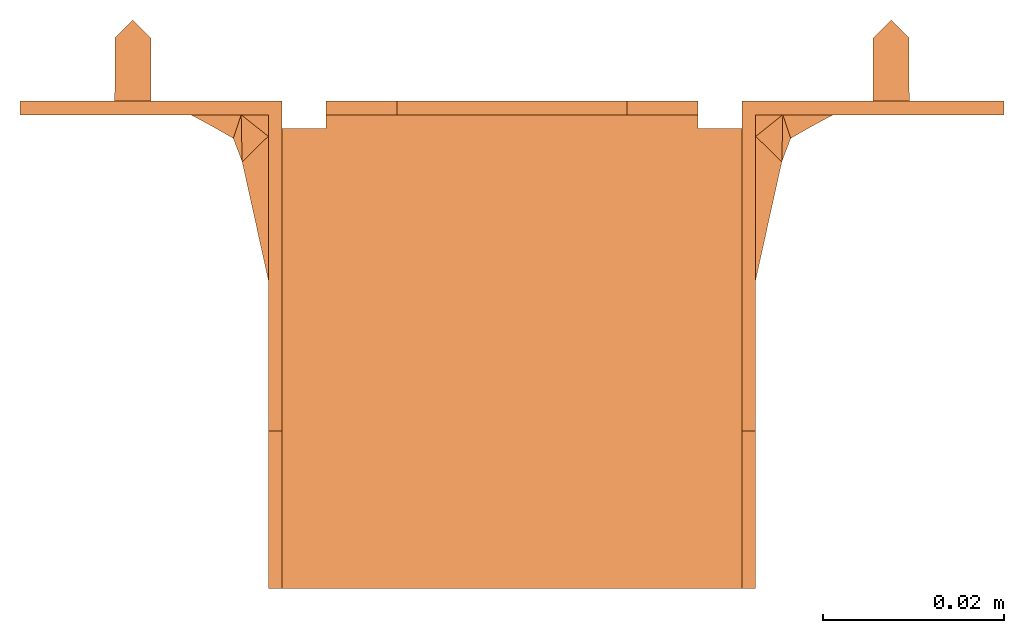
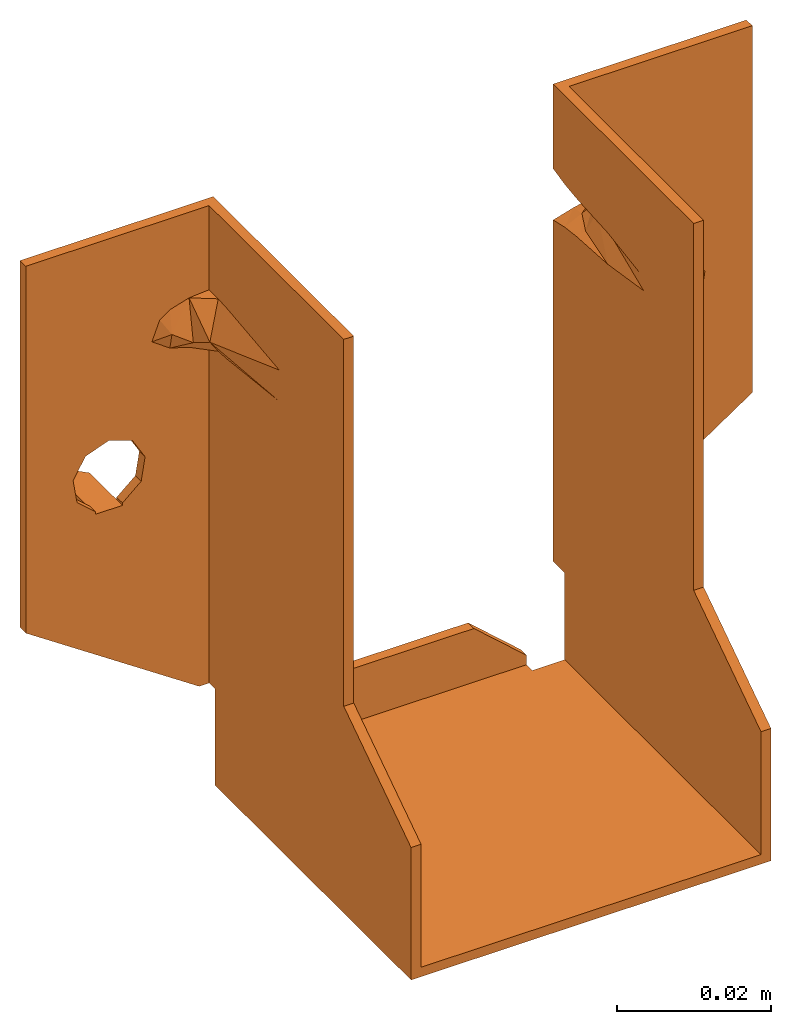
# One storey: 1 proxy.
"""IFC2X3 building model written with IfcOpenShell, lengths in millimetres."""

from ifc_helpers import new_model, entity, si_unit, converted_unit, derived_unit, direction, origin, place, context, subcontext, project, spatial, faceted_brep, source, transform, mapped, material, element, save


model = new_model("IFC2X3")

# Units and contexts
model_context = context("Model", 3, precision=0.01, world=origin(), true_north=direction((6.12303176911189e-17, 1.0)))
context_of_model = context(None, 3, precision=0.01, world=origin(), true_north=direction((6.12303176911189e-17, 1.0)))
body_context = subcontext(model_context, "Body", "Model", "MODEL_VIEW")
ifc_project = project(units=[si_unit("LENGTHUNIT", "METRE", prefix="MILLI"), converted_unit("AREAUNIT", "SQUARE FOOT", entity("IfcRatioMeasure", 0.09290304), si_unit("AREAUNIT", "SQUARE_METRE"), dimensions=[2, 0, 0, 0, 0, 0, 0]), converted_unit("VOLUMEUNIT", "CUBIC FOOT", entity("IfcRatioMeasure", 0.028316846592), si_unit("VOLUMEUNIT", "CUBIC_METRE"), dimensions=[3, 0, 0, 0, 0, 0, 0]), converted_unit("PLANEANGLEUNIT", "DEGREE", entity("IfcRatioMeasure", 0.0174532925199433), si_unit("PLANEANGLEUNIT", "RADIAN"), dimensions=[0, 0, 0, 0, 0, 0, 0]), si_unit("MASSUNIT", "GRAM", prefix="KILO"), si_unit("TIMEUNIT", "SECOND"), si_unit("FREQUENCYUNIT", "HERTZ"), si_unit("THERMODYNAMICTEMPERATUREUNIT", "DEGREE_CELSIUS"), derived_unit("THERMALTRANSMITTANCEUNIT", [(si_unit("MASSUNIT", "GRAM", prefix="KILO"), 1), (si_unit("THERMODYNAMICTEMPERATUREUNIT", "KELVIN"), -1), (si_unit("TIMEUNIT", "SECOND"), -3)]), derived_unit("VOLUMETRICFLOWRATEUNIT", [(si_unit("LENGTHUNIT", "METRE"), 3), (si_unit("TIMEUNIT", "SECOND"), -1)]), si_unit("ELECTRICCURRENTUNIT", "AMPERE"), si_unit("ELECTRICVOLTAGEUNIT", "VOLT"), si_unit("POWERUNIT", "WATT"), si_unit("FORCEUNIT", "NEWTON"), si_unit("ILLUMINANCEUNIT", "LUX"), si_unit("LUMINOUSFLUXUNIT", "LUMEN"), si_unit("LUMINOUSINTENSITYUNIT", "CANDELA"), si_unit("PRESSUREUNIT", "PASCAL")], contexts=[model_context, context_of_model])

# Site, building, storey
site_placement = place(None, origin())
site = spatial("IfcSite", under=ifc_project, at=site_placement, CompositionType="ELEMENT")
building_placement = place(site_placement, origin())
building = spatial("IfcBuilding", under=site, at=building_placement, CompositionType="ELEMENT")
storey_placement = place(building_placement, origin())
storey = spatial("IfcBuildingStorey", under=building, at=storey_placement, Name="Level 1", CompositionType="ELEMENT", Elevation=0.0)

# Proxy
ifc_material = material(Name="Galvanised")
shared_shape = source(origin(), body_context, "Body", "Brep", [
    faceted_brep([(-25.5, 0.0, 89.5), (-25.5000000000001, 0.0, 76.0680447925519), (-28.5164626396647, 0.0, 75.1703317636631), (-31.5853310986962, 0.0, 74.4944747377399), (-31.9884182385809, 0.0, 74.4262128764024), (-32.3912057400425, 0.0, 74.35627635071), (-54.5, 0.0, 89.5), (-35.1100733723525, 0.0, 72.9234667501482), (-36.8624233395133, 0.0, 72.0), (-34.1435557017103, 0.0, 70.5671903965434), (-42.0, 0.0, 57.5), (-32.3912057400424, 0.0, 69.64372364929), (-38.4911282799051, 0.0, 56.2353062760463), (-31.988418238207, 0.0, 69.573787123533), (-31.5853310979541, 0.0, 69.5055252620951), (-28.5164626393064, 0.0, 68.8296682361884), (-25.5, 0.0, 67.9319552074545), (-36.5959467571056, 0.0, 53.0228433643336), (-37.1860278598334, 0.0, 49.3399864222716), (-25.5, 0.0, 13.7727785620969), (-40.0, 0.0, 45.0), (-28.5, 0.0, 13.7727785620969), (-54.5, 0.0, 31.31), (-44.0, 0.0, 45.0), (-46.8139721401667, 0.0, 49.3399864222716), (-47.4040532428946, 0.0, 53.0228433643336), (-45.5088717200951, 0.0, 56.2353062760463), (-44.0050000000001, 0.0, 46.5), (-44.0100000000001, 0.0, 46.8804394719859), (-39.9950000000001, 0.0, 46.5), (-39.9900000000001, 0.0, 46.8804394719859), (25.5000000000002, 0.0, 89.5), (54.5000000000002, 0.0, 89.5), (32.3912057400424, 0.0, 74.35627635071), (31.9884182385809, 0.0, 74.4262128764024), (31.5853310986874, 0.0, 74.4944747376867), (28.5164626396627, 0.0, 75.1703317636636), (25.5000000000001, 0.0, 76.0680447925519), (35.1100733723523, 0.0, 72.9234667501483), (36.8624233395133, 0.0, 72.0), (45.5088717200951, 0.0, 56.2353062760463), (47.4040532428946, 0.0, 53.0228433643336), (54.5000000000001, 0.0, 31.31), (46.8139721401668, 0.0, 49.3399864222716), (44.0, 0.0, 45.0), (40.0, 0.0, 45.0), (28.5, 0.0, 13.7727785620969), (25.5, 0.0, 13.7727785620969), (37.1860278598334, 0.0, 49.3399864222716), (25.5000000000001, 0.0, 67.9319552074546), (36.5959467571056, 0.0, 53.0228433643336), (38.4911282799051, 0.0, 56.2353062760463), (28.5164626393065, 0.0, 68.8296682361884), (31.5853310979472, 0.0, 69.505525262137), (31.988418238207, 0.0, 69.573787123533), (32.3912057400424, 0.0, 69.64372364929), (42.0, 0.0, 57.5), (34.1435557017102, 0.0, 70.5671903965434), (39.9950000000001, 0.0, 46.5), (39.9900000000001, 0.0, 46.8804394719859), (44.0050000000001, 0.0, 46.5), (44.0100000000001, 0.0, 46.8804394719859), (-12.75, 0.0, 8.5), (12.75, 0.0, 8.5), (20.625, 0.0, 1.50000000000001), (20.625, 0.0, -1.49999999999998), (-20.625, 0.0, -1.49999999999999), (-20.625, 0.0, 1.5), (-27.0, -1.5, 89.5), (-27.0, -19.7785075183965, 74.4781276587163), (-27.0, -36.5, 89.5), (-27.0, -6.25628514900084, 76.0015865398657), (-27.0, -3.88236220929079, 76.159855910213), (-27.0, -1.50000000000001, 76.1478993905245), (-27.0, -24.9500000000007, 72.0), (-27.0, -19.7785075183964, 69.5218723412837), (-27.0, -36.5, 31.31), (-27.0, -6.25628514899862, 67.9984134601342), (-27.0, -3.0, 13.7727785620969), (-27.0, -3.89258332769992, 67.8407422939264), (-27.0, -1.5, 67.8521006094755), (-27.0, -1.5, 13.7727785620969), (-27.0, -3.0, -1.49999999999999), (-27.0, -54.0, -1.49999999999999), (-27.0, -54.0, 19.5061009552575), (27.0, -36.5, 31.31), (27.0, -54.0, 19.5061009552576), (27.0, -54.0, -1.49999999999998), (27.0, -3.0, -1.49999999999998), (27.0, -3.0, 13.7727785620969), (27.0, -6.25628514900161, 67.9984134601343), (27.0, -19.7785075183968, 69.5218723412838), (27.0, -24.950000000001, 72.0), (27.0, -36.5, 89.5), (27.0, -3.88236220929137, 67.8401440897871), (27.0, -1.50000000000116, 67.8521006094754), (27.0, -1.49999999999999, 13.7727785620969), (27.0, -19.7785075183969, 74.4781276587163), (27.0, -1.50000000000001, 89.5), (27.0, -6.25628514899864, 76.0015865398658), (27.0, -3.89258332769992, 76.1592577060736), (27.0, -1.5, 76.1478993905245), (-28.3744321404696, -2.48961956164226, 69.505525262095), (-26.1302855306788, -6.11853590953504, 69.2411981416627), (-25.5, -2.98683164318899, 68.5972304361922), (-25.5000000000001, -6.01870848852047, 68.9768710212308), (-26.7605710613576, -6.21836333055625, 69.505525262095), (-20.625, -1.5, 0.0), (-20.625, -1.5, 1.5), (-20.625, -3.0, -1.5), (-20.625, -3.0, 0.0), (20.625, -1.5, 1.50000000000001), (20.625, -1.5, 0.0), (20.625, -3.0, 0.0), (20.625, -3.0, -1.49999999999999), (-25.5, -3.0, 13.7727785620969), (-25.5, -3.0, 0.0), (25.5, -3.0, 0.0), (25.5, -3.0, 13.7727785620969), (12.75, -1.50000000000001, 8.5), (-12.75, -1.50000000000001, 8.5), (-30.001194607727, -1.50000000000001, 75.9217007968475), (-32.8785852843918, -1.50000000000001, 75.0423700295935), (-54.5, -1.50000000000001, 89.5), (-34.4052679931513, -1.50000000000001, 73.942091087405), (-37.1000000000001, -1.50000000000001, 72.0), (-45.5088717200951, -1.50000000000001, 56.2353062760463), (-47.4040532428946, -1.50000000000001, 53.0228433643336), (-54.5000000000001, -1.50000000000001, 31.31), (-46.8139721401667, -1.50000000000001, 49.3399864222716), (-44.0100000000001, -1.50000000000001, 46.5), (-39.9900000000001, -1.50000000000001, 46.5), (-28.5, -1.49999999999999, 13.7727785620969), (-37.1860278598334, -1.50000000000001, 49.3399864222716), (-36.5959467571056, -1.50000000000001, 53.0228433643336), (-29.9983767666607, -1.50000000000001, 68.0776222514754), (-38.4911282799051, -1.50000000000001, 56.2353062760463), (-32.8785852843918, -1.50000000000001, 68.9576299704065), (-42.0, -1.50000000000001, 57.5), (-35.5733172762352, -1.50000000000001, 70.8997210469971), (-39.9900000000001, -1.50000000000001, 46.8804394719859), (-44.0100000000001, -1.50000000000001, 46.8804394719859), (54.5000000000002, -1.50000000000001, 89.5), (32.8785852843917, -1.50000000000001, 75.0423700295936), (34.405267993151, -1.5, 73.9420910874052), (37.1000000000001, -1.50000000000001, 72.0), (45.5088717200951, -1.50000000000001, 56.2353062760463), (47.4040532428946, -1.50000000000001, 53.0228433643336), (54.5000000000001, -1.50000000000001, 31.31), (29.9983767666607, -1.50000000000001, 75.9223777485246), (35.5733172762347, -1.50000000000001, 70.8997210469968), (42.0, -1.50000000000001, 57.5), (32.8785852843918, -1.50000000000001, 68.9576299704064), (38.4911282799051, -1.50000000000001, 56.2353062760463), (30.0011946077271, -1.50000000000001, 68.0782992031525), (36.5959467571056, -1.50000000000001, 53.0228433643336), (37.1860278598334, -1.50000000000001, 49.3399864222716), (39.9900000000001, -1.50000000000001, 46.5), (28.5, -1.5, 13.7727785620969), (44.0100000000001, -1.50000000000001, 46.5), (39.9900000000001, -1.50000000000001, 46.8804394719859), (46.8139721401668, -1.50000000000001, 49.3399864222716), (44.0100000000001, -1.50000000000001, 46.8804394719859), (-25.5, -54.0, 0.0), (25.5, -54.0, 0.0), (25.5, -54.0, 19.5061009552576), (25.5, -36.5, 31.31), (25.5, -36.5, 89.5), (25.5, -2.98683164319337, 75.4027695637694), (25.5, -6.01870848851384, 75.0231289787069), (25.5, -14.1772957805425, 74.4944747377333), (25.5, -23.518136815564, 73.0332452672442), (25.5, -23.5181368147413, 70.9667547324451), (25.5, -14.1772957785577, 69.5055252620951), (25.5, -6.01870848852039, 68.9768710212309), (25.5, -2.98683164318892, 68.5972304361922), (-25.5, -14.1772957804188, 74.4944747376867), (-25.5, -6.01870848853966, 75.0231289787052), (-25.5, -2.98683164319346, 75.4027695637694), (-25.5, -36.5, 89.5), (-25.5, -36.5, 31.31), (-25.5, -54.0, 19.5061009552576), (-25.5, -14.1772957785561, 69.505525262138), (-25.5, -23.5181368147411, 70.9667547324451), (-25.5, -23.5181368155638, 73.0332452672442), (-44.0, 7.0, 46.5), (-44.0, 7.0, 45.0), (-40.0, 7.0, 46.5), (-42.0, 9.0, 46.5), (42.0, 9.0, 46.5), (40.0, 7.0, 46.5), (44.0, 7.0, 46.5), (-40.0, 7.0, 45.0), (-42.0, 9.0, 45.0), (40.0, 7.0, 45.0), (42.0, 9.0, 45.0), (44.0, 7.0, 45.0), (-26.1302855308225, -6.1185359095578, 74.7588018581968), (-28.3744321409058, -2.4896195615548, 74.4944747376867), (-26.7605710616451, -6.21836333060179, 74.4944747376867), (28.3744321409058, -2.48961956155479, 74.4944747376867), (26.1302855308226, -6.11853590955781, 74.7588018581968), (26.7605710616451, -6.21836333060177, 74.4944747376867), (26.1302855306789, -6.11853590953505, 69.2411981416627), (28.3744321404696, -2.48961956164225, 69.505525262095), (26.7605710613576, -6.21836333055626, 69.505525262095), (29.7145212288949, -3.12964418156914, 70.925388446779), (29.7808364477858, -3.18628278965097, 72.8456687581006), (32.8181690280177, -1.3140578823797, 72.0), (28.4068052775864, -6.47910121553675, 72.0), (29.8883377884792, -6.71375291309711, 72.0), (30.8677440361431, -4.11458986984205, 70.699321432539), (33.2816945195801, -2.7406426568225, 72.0), (-28.4068052775865, -6.47910121553677, 72.0), (-32.8181690280177, -1.31405788237978, 72.0), (-29.7145212041196, -3.12964423075594, 70.9253884769854), (-29.7808364632599, -3.18628274887455, 72.8456688027196), (-29.8883377884792, -6.71375291309711, 72.0), (-33.2816945195801, -2.7406426568225, 72.0), (-30.8676578625908, -4.11451627066118, 70.6989735355985)], [[[0, 1, 2]], [[0, 2, 3]], [[0, 3, 4]], [[5, 0, 4]], [[0, 5, 6]], [[6, 5, 7]], [[6, 7, 8]], [[9, 8, 7]], [[10, 8, 9]], [[10, 9, 11]], [[10, 11, 12]], [[12, 11, 13]], [[12, 13, 14]], [[12, 14, 15]], [[15, 16, 12]], [[17, 12, 16]], [[17, 16, 18]], [[16, 19, 18]], [[20, 18, 19]], [[19, 21, 20]], [[20, 21, 22]], [[23, 20, 22]], [[24, 23, 22]], [[25, 24, 22]], [[25, 22, 6]], [[6, 8, 26]], [[26, 25, 6]], [[23, 24, 27]], [[28, 27, 24]], [[20, 29, 18]], [[30, 18, 29]], [[26, 8, 10]], [[0, 1, 2]], [[0, 2, 3]], [[0, 3, 4]], [[5, 0, 4]], [[0, 5, 6]], [[6, 5, 7]], [[6, 7, 8]], [[9, 8, 7]], [[10, 8, 9]], [[10, 9, 11]], [[10, 11, 12]], [[12, 11, 13]], [[12, 13, 14]], [[12, 14, 15]], [[15, 16, 12]], [[17, 12, 16]], [[17, 16, 18]], [[16, 19, 18]], [[20, 18, 19]], [[19, 21, 20]], [[20, 21, 22]], [[23, 20, 22]], [[24, 23, 22]], [[25, 24, 22]], [[25, 22, 6]], [[6, 8, 26]], [[26, 25, 6]], [[23, 24, 27]], [[28, 27, 24]], [[20, 29, 18]], [[30, 18, 29]], [[26, 8, 10]], [[31, 32, 33]], [[31, 33, 34]], [[31, 34, 35]], [[36, 31, 35]], [[31, 36, 37]], [[32, 38, 33]], [[32, 39, 38]], [[39, 32, 40]], [[41, 40, 32]], [[41, 32, 42]], [[43, 41, 42]], [[43, 42, 44]], [[42, 45, 44]], [[45, 42, 46]], [[46, 47, 45]], [[45, 47, 48]], [[48, 47, 49]], [[48, 49, 50]], [[51, 50, 49]], [[52, 51, 49]], [[51, 52, 53]], [[54, 51, 53]], [[51, 54, 55]], [[55, 56, 51]], [[56, 55, 57]], [[57, 38, 39]], [[56, 57, 39]], [[40, 56, 39]], [[45, 48, 58]], [[59, 58, 48]], [[60, 43, 44]], [[43, 60, 61]], [[62, 63, 64, 65, 66, 67]], [[68, 69, 70]], [[71, 69, 68]], [[71, 68, 72]], [[73, 72, 68]], [[74, 70, 69]], [[69, 75, 74]], [[76, 74, 75]], [[76, 75, 77]], [[76, 77, 78]], [[77, 79, 78]], [[78, 79, 80]], [[80, 81, 78]], [[78, 82, 76]], [[83, 76, 82]], [[76, 83, 84]], [[74, 76, 70]], [[85, 86, 87]], [[88, 85, 87]], [[89, 85, 88]], [[89, 90, 85]], [[85, 90, 91]], [[85, 91, 92]], [[93, 85, 92]], [[90, 89, 94]], [[94, 89, 95]], [[96, 95, 89]], [[91, 97, 92]], [[98, 93, 97]], [[92, 97, 93]], [[98, 97, 99]], [[99, 100, 98]], [[98, 100, 101]], [[102, 103, 104]], [[103, 105, 104]], [[102, 106, 103]], [[15, 14, 102]], [[15, 104, 16]], [[102, 104, 15]], [[107, 108, 67, 66, 109, 110]], [[111, 112, 113, 114, 65, 64]], [[110, 109, 82, 78, 115, 116]], [[117, 118, 89, 88, 114, 113]], [[107, 112, 111, 119, 120, 108]], [[107, 120, 108]], [[120, 107, 112]], [[112, 119, 120]], [[119, 112, 111]], [[121, 73, 68]], [[122, 121, 68]], [[68, 123, 122]], [[123, 124, 122]], [[123, 125, 124]], [[126, 125, 123]], [[127, 126, 123]], [[123, 128, 127]], [[128, 129, 127]], [[129, 128, 130]], [[130, 128, 131]], [[128, 132, 131]], [[132, 81, 131]], [[133, 131, 81]], [[133, 81, 80]], [[133, 80, 134]], [[134, 80, 135]], [[135, 136, 134]], [[135, 137, 136]], [[137, 138, 136]], [[138, 137, 139]], [[125, 139, 124]], [[138, 139, 125]], [[125, 126, 138]], [[131, 133, 140]], [[141, 129, 130]], [[107, 120, 108]], [[120, 107, 112]], [[112, 119, 120]], [[119, 112, 111]], [[121, 73, 68]], [[122, 121, 68]], [[68, 123, 122]], [[123, 124, 122]], [[123, 125, 124]], [[126, 125, 123]], [[127, 126, 123]], [[123, 128, 127]], [[128, 129, 127]], [[129, 128, 130]], [[130, 128, 131]], [[128, 132, 131]], [[132, 81, 131]], [[133, 131, 81]], [[133, 81, 80]], [[133, 80, 134]], [[134, 80, 135]], [[135, 136, 134]], [[135, 137, 136]], [[137, 138, 136]], [[138, 137, 139]], [[125, 139, 124]], [[138, 139, 125]], [[125, 126, 138]], [[131, 133, 140]], [[141, 129, 130]], [[142, 143, 144]], [[143, 142, 98]], [[142, 144, 145]], [[146, 142, 145]], [[146, 147, 142]], [[148, 142, 147]], [[143, 98, 149]], [[101, 149, 98]], [[150, 145, 144]], [[151, 145, 150]], [[151, 150, 152]], [[151, 152, 153]], [[153, 152, 154]], [[154, 155, 153]], [[154, 95, 155]], [[155, 95, 156]], [[95, 96, 156]], [[156, 96, 157]], [[96, 158, 157]], [[148, 157, 158]], [[148, 159, 157]], [[156, 157, 160]], [[146, 145, 151]], [[148, 147, 161]], [[162, 159, 161]], [[148, 161, 159]], [[163, 164, 117, 113, 112, 107, 110, 116]], [[78, 81, 132, 21, 19, 115]], [[96, 89, 118, 47, 46, 158]], [[164, 165, 166, 167, 31, 37, 168, 169, 170, 171, 172, 173, 174, 175, 49, 47, 118, 117]], [[82, 109, 66, 65, 114, 88, 87, 83]], [[176, 177, 178, 1, 0, 179, 180, 181, 163, 116, 115, 19, 16, 104, 105, 182, 183, 184]], [[23, 27, 185]], [[185, 186, 23]], [[185, 27, 130, 131, 29, 187, 188]], [[189, 190, 58, 157, 159, 60, 191]], [[192, 187, 20]], [[29, 20, 187]], [[186, 193, 192, 20, 23]], [[194, 195, 196, 44, 45]], [[191, 60, 44]], [[44, 196, 191]], [[45, 190, 194]], [[190, 45, 58]], [[160, 157, 58]], [[58, 59, 160]], [[28, 141, 27]], [[130, 27, 141]], [[29, 131, 140]], [[140, 30, 29]], [[159, 162, 61]], [[61, 60, 159]], [[22, 128, 123, 6]], [[148, 42, 32, 142]], [[178, 197, 198]], [[178, 177, 197]], [[197, 199, 198]], [[198, 3, 2]], [[1, 178, 2]], [[2, 178, 198]], [[200, 201, 168]], [[201, 169, 168]], [[200, 202, 201]], [[36, 35, 200]], [[36, 168, 37]], [[200, 168, 36]], [[175, 203, 204]], [[175, 174, 203]], [[203, 205, 204]], [[204, 53, 52]], [[49, 175, 52]], [[52, 175, 204]], [[205, 206, 204]], [[207, 208, 206]], [[209, 206, 205]], [[209, 202, 207]], [[207, 206, 209]], [[207, 34, 33]], [[206, 208, 55]], [[200, 207, 202]], [[208, 207, 33]], [[206, 55, 54]], [[206, 53, 204]], [[34, 200, 35]], [[34, 207, 200]], [[206, 54, 53]], [[90, 94, 210]], [[149, 100, 210]], [[149, 211, 212]], [[100, 99, 210]], [[149, 101, 100]], [[94, 154, 211]], [[152, 212, 211]], [[211, 154, 152]], [[149, 212, 143]], [[210, 211, 149]], [[94, 211, 210]], [[154, 94, 95]], [[179, 70, 76, 180]], [[93, 167, 166, 85]], [[98, 142, 32, 31, 167, 93]], [[6, 123, 68, 70, 179, 0]], [[18, 30, 140, 133]], [[133, 134, 17, 18]], [[17, 134, 136, 12]], [[138, 10, 12, 136]], [[25, 26, 126, 127]], [[127, 129, 24, 25]], [[24, 129, 141, 28]], [[126, 26, 10, 138]], [[197, 177, 176, 199]], [[213, 176, 184]], [[199, 176, 213]], [[182, 106, 213]], [[213, 183, 182]], [[184, 183, 213]], [[106, 182, 105, 103]], [[7, 5, 214]], [[214, 11, 9]], [[9, 7, 214]], [[106, 102, 215]], [[215, 11, 214]], [[215, 214, 216]], [[213, 216, 199]], [[213, 215, 216]], [[106, 215, 213]], [[4, 216, 5]], [[199, 216, 198]], [[5, 216, 214]], [[13, 11, 215]], [[102, 14, 215]], [[3, 198, 4]], [[198, 216, 4]], [[215, 14, 13]], [[217, 79, 77]], [[217, 72, 121]], [[218, 219, 121]], [[217, 71, 72]], [[72, 73, 121]], [[219, 135, 79]], [[219, 218, 137]], [[137, 135, 219]], [[122, 218, 121]], [[121, 219, 217]], [[217, 219, 79]], [[80, 79, 135]], [[218, 124, 139]], [[137, 218, 139]], [[124, 218, 122]], [[71, 217, 69]], [[69, 217, 75]], [[75, 217, 77]], [[21, 132, 128, 22]], [[67, 108, 120, 62]], [[63, 119, 111, 64]], [[63, 62, 120, 119]], [[85, 166, 165, 86]], [[180, 76, 84, 181]], [[156, 160, 59, 48]], [[50, 155, 156, 48]], [[155, 50, 51, 153]], [[56, 151, 153, 51]], [[146, 151, 56, 40]], [[41, 147, 146, 40]], [[147, 41, 43, 161]], [[43, 61, 162, 161]], [[38, 208, 33]], [[38, 57, 208]], [[55, 208, 57]], [[209, 170, 202]], [[171, 170, 209]], [[209, 173, 172]], [[173, 209, 205]], [[171, 209, 172]], [[170, 169, 201, 202]], [[203, 174, 173, 205]], [[99, 97, 210]], [[210, 97, 91]], [[91, 90, 210]], [[212, 152, 150]], [[212, 150, 144]], [[144, 143, 212]], [[42, 148, 158, 46]], [[181, 84, 83, 87, 86, 165, 164, 163]], [[190, 189, 195, 194]], [[195, 189, 191, 196]], [[193, 188, 187, 192]], [[186, 185, 188, 193]]]),
])
proxy_placement = place(storey_placement, origin())
element("IfcBuildingElementProxy", 1, at=proxy_placement, inside=storey, material=ifc_material, CompositionType="ELEMENT", context=body_context, shape_type="MappedRepresentation", body=[
    mapped(shared_shape, transform((0.0, 0.0, 0.0), scale=1.0)),
])

save(model, "model.ifc")
